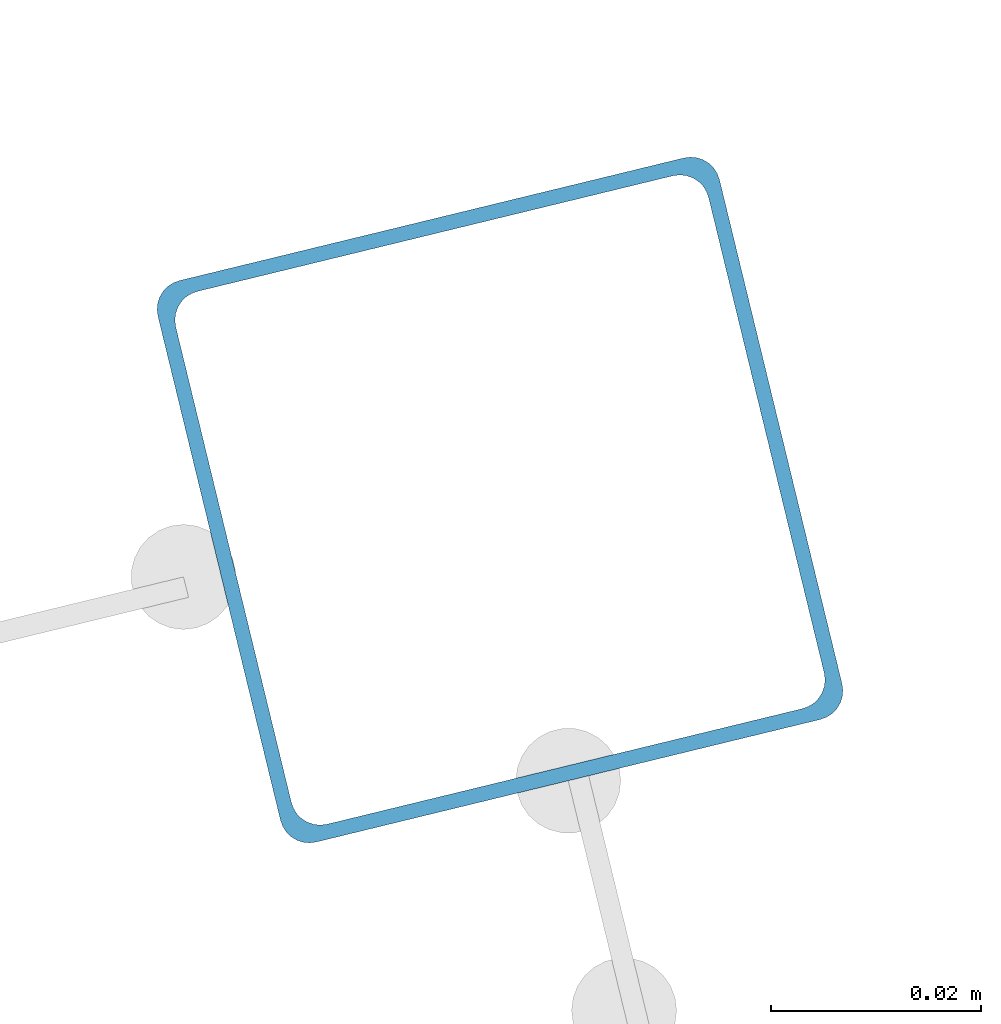
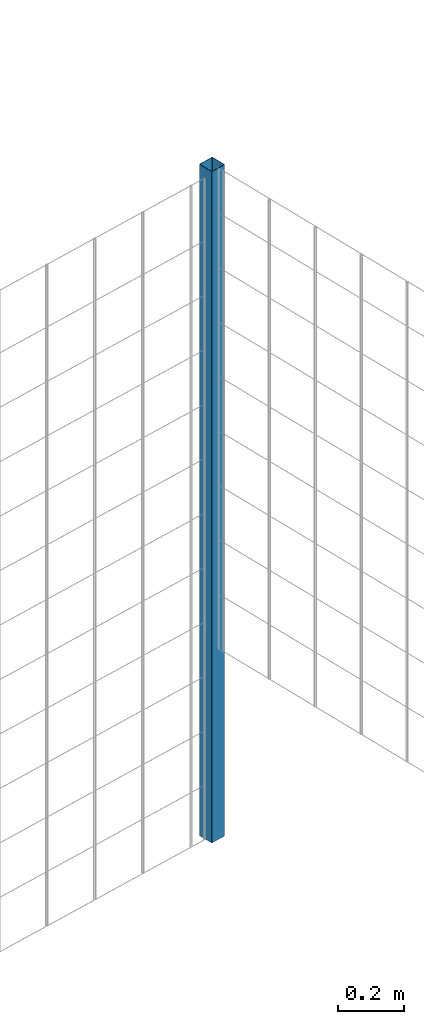
# One storey, part 5 of 10: 1 beam.
"""IFC2X3 building model written with IfcOpenShell, lengths in millimetres."""

import ifcopenshell
import ifcopenshell.guid

model = None  # the IFC model being written
_history = None  # IfcOwnerHistory: only IFC2X3 demands one
_inside = {}  # id of a spatial element -> (the spatial element, [elements in it])
_under = {}  # id of a project, library or spatial element -> (it, [spatial elements below it])
_declared = {}  # id of a project -> (the project, [libraries it declares])
_typed = {}  # id of a type object -> (the type object, [elements of that type])
_made_of = {}  # id of a material, layer set ... -> (it, [elements and type objects made of it])


def new_model(schema):
    """Start an empty IFC model of exactly this schema.

    Asked for "IFC4X3", IfcOpenShell would pick the latest addendum, in which some entities
    have other attributes; the version numbers below select the first issue.
    IFC2X3 requires an IfcOwnerHistory on every rooted entity: one is made here for all.
    """
    global model, _history
    if schema == "IFC4X3":
        model = ifcopenshell.file(schema_version=(4, 3, 0, 0))
    else:
        model = ifcopenshell.file(schema=schema)
    _inside.clear()
    _under.clear()
    _declared.clear()
    _typed.clear()
    _made_of.clear()
    _history = None
    if model.schema == "IFC2X3":
        org = make("IfcOrganization", Name="unknown")
        user = make(
            "IfcPersonAndOrganization",
            ThePerson=make("IfcPerson", FamilyName="unknown"),
            TheOrganization=org,
        )
        app = make(
            "IfcApplication",
            ApplicationDeveloper=org,
            Version="unknown",
            ApplicationFullName="unknown",
            ApplicationIdentifier="unknown",
        )
        _history = make(
            "IfcOwnerHistory",
            OwningUser=user,
            OwningApplication=app,
            ChangeAction="ADDED",
            CreationDate=0,
        )
    return model


def make(cls, **values):
    """One entity of the class cls with the attributes given. An attribute that is None is left unset."""
    return model.create_entity(
        cls, **{name: value for name, value in values.items() if value is not None}
    )


def entity(cls, *values):
    """Any entity or typed value of the class cls, its attributes in the order of the schema. None: left unset."""
    e = model.create_entity(cls)
    for i, value in enumerate(values):
        if value is not None:
            e[i] = value
    return e


def rooted(cls, **values):
    """An entity with a GlobalId (a new one), such as an element, a storey or a relation."""
    return make(cls, GlobalId=ifcopenshell.guid.new(), OwnerHistory=_history, **values)


def si_unit(unit_type, name, prefix=None):
    """IfcSIUnit, for example si_unit("LENGTHUNIT", "METRE", prefix="MILLI")."""
    return make("IfcSIUnit", UnitType=unit_type, Prefix=prefix, Name=name)


def converted_unit(unit_type, name, factor, base, dimensions=None, offset=None):
    """IfcConversionBasedUnit, such as the inch: factor (a typed value) times the base unit."""
    return make(
        "IfcConversionBasedUnit"
        if offset is None
        else "IfcConversionBasedUnitWithOffset",
        ConversionOffset=offset,
        Dimensions=None
        if dimensions is None
        else entity("IfcDimensionalExponents", *dimensions),
        UnitType=unit_type,
        Name=name,
        ConversionFactor=make(
            "IfcMeasureWithUnit", ValueComponent=factor, UnitComponent=base
        ),
    )


def derived_unit(unit_type, elements):
    """IfcDerivedUnit: a product of units, each with its exponent."""
    return make(
        "IfcDerivedUnit",
        Elements=[
            make("IfcDerivedUnitElement", Unit=unit, Exponent=power)
            for unit, power in elements
        ],
        UnitType=unit_type,
    )


def assignment(units):
    """IfcUnitAssignment: the units of a project."""
    return None if units is None else make("IfcUnitAssignment", Units=units)


def point(xyz):
    """IfcCartesianPoint."""
    return None if xyz is None else make("IfcCartesianPoint", Coordinates=xyz)


def direction(xyz):
    """IfcDirection."""
    return None if xyz is None else make("IfcDirection", DirectionRatios=xyz)


def frame(location, z_axis=None, x_axis=None):
    """IfcAxis2Placement3D, a coordinate frame: its origin and axes. An axis left out is left unset."""
    return make(
        "IfcAxis2Placement3D",
        Location=point(location),
        Axis=direction(z_axis),
        RefDirection=direction(x_axis),
    )


def frame_2d(location, x_axis=None):
    """IfcAxis2Placement2D, a coordinate frame in the plane: its origin and x axis."""
    return make(
        "IfcAxis2Placement2D", Location=point(location), RefDirection=direction(x_axis)
    )


def origin():
    """The frame at (0, 0, 0) with its axes left unset."""
    return frame((0.0, 0.0, 0.0))


def place(relative_to, where):
    """IfcLocalPlacement: puts the frame where relative to a parent placement (None: the world)."""
    return make(
        "IfcLocalPlacement", PlacementRelTo=relative_to, RelativePlacement=where
    )


def context(
    kind, dimensions, precision=None, world=None, true_north=None, identifier=None
):
    """IfcGeometricRepresentationContext, for example the 3D "Model" context."""
    return make(
        "IfcGeometricRepresentationContext",
        ContextIdentifier=identifier,
        ContextType=kind,
        CoordinateSpaceDimension=dimensions,
        Precision=precision,
        WorldCoordinateSystem=world,
        TrueNorth=true_north,
    )


def subcontext(parent, identifier, kind, view, scale=None):
    """IfcGeometricRepresentationSubContext, for example "Body" below "Model"."""
    return make(
        "IfcGeometricRepresentationSubContext",
        ContextIdentifier=identifier,
        ContextType=kind,
        ParentContext=parent,
        TargetScale=scale,
        TargetView=view,
    )


def project(units=None, contexts=None):
    """IfcProject with its units and contexts."""
    return rooted(
        "IfcProject",
        Name="project",
        RepresentationContexts=contexts,
        UnitsInContext=assignment(units),
    )


def spatial(cls, under=None, at=None, **own):
    """A site, building, storey or space (cls), placed at a placement, below another one or the project."""
    s = rooted(cls, ObjectPlacement=at, **own)
    if under is not None:
        _under.setdefault(under.id(), (under, []))[1].append(s)
    return s


def polyline(points):
    """IfcPolyline through the points."""
    return make("IfcPolyline", Points=[point(p) for p in points])


def circle_curve(where, radius):
    """IfcCircle in the frame where."""
    return make("IfcCircle", Position=where, Radius=radius)


def parameter(value):
    """IfcParameterValue: where a trimmed curve begins or ends, as a parameter of its basis curve."""
    return model.create_entity("IfcParameterValue", value)


def trimmed(basis, trim1, trim2, sense, master):
    """IfcTrimmedCurve: the piece of a basis curve between two trims."""
    return make(
        "IfcTrimmedCurve",
        BasisCurve=basis,
        Trim1=trim1,
        Trim2=trim2,
        SenseAgreement=sense,
        MasterRepresentation=master,
    )


def segment(curve, same_sense, transition):
    """IfcCompositeCurveSegment."""
    return make(
        "IfcCompositeCurveSegment",
        Transition=transition,
        SameSense=same_sense,
        ParentCurve=curve,
    )


def composite_curve(segments, self_intersect=None):
    """IfcCompositeCurve: segments joined end to end."""
    return make("IfcCompositeCurve", Segments=segments, SelfIntersect=self_intersect)


def outline(outer, holes=None, kind="AREA"):
    """IfcArbitraryClosedProfileDef: a profile drawn as a closed curve; with holes, ...WithVoids."""
    if holes is None:
        return make("IfcArbitraryClosedProfileDef", ProfileType=kind, OuterCurve=outer)
    return make(
        "IfcArbitraryProfileDefWithVoids",
        ProfileType=kind,
        OuterCurve=outer,
        InnerCurves=holes,
    )


def extrude(swept, where, along, depth):
    """IfcExtrudedAreaSolid: the profile swept, set in the frame where, extruded along a direction by depth."""
    return make(
        "IfcExtrudedAreaSolid",
        SweptArea=swept,
        Position=where,
        ExtrudedDirection=direction(along),
        Depth=depth,
    )


def shape(context_of_items, identifier, shape_type, items):
    """IfcShapeRepresentation: the items that make up one representation, for example the "Body"."""
    return make(
        "IfcShapeRepresentation",
        ContextOfItems=context_of_items,
        RepresentationIdentifier=identifier,
        RepresentationType=shape_type,
        Items=items,
    )


def material(Name=None, Category=None):
    """IfcMaterial."""
    return make("IfcMaterial", Name=Name, Category=Category)


def made_of(thing, what):
    """Note that an element or type object is made of a material, layer set ...; save() writes the relation."""
    if what is not None:
        _made_of.setdefault(what.id(), (what, []))[1].append(thing)
    return thing


def type_object(cls, material=None, **own):
    """A type object (cls), such as IfcWallType, which elements share."""
    return made_of(rooted(cls, **own), material)


def element(
    cls,
    number,
    at=None,
    inside=None,
    cuts=None,
    type_object=None,
    material=None,
    context=None,
    identifier="Body",
    shape_type=None,
    held_by="IfcProductDefinitionShape",
    body=None,
    shapes=None,
    **own,
):
    """One element of the class cls, such as IfcWall. Its Tag is "e" and its number.

    at: its placement. inside: the storey or other place that contains it. cuts: it is an
    opening in that element (IfcRelVoidsElement). A single representation is given by context,
    identifier, shape_type and body (its items); several are given by shapes. held_by: the class
    of the entity that holds the representations. save() writes the other relations.
    """
    e = rooted(cls, Tag="e%d" % number, ObjectPlacement=at, **own)
    if body is not None:
        shapes = [shape(context, identifier, shape_type, body)]
    if shapes is not None:
        e.Representation = make(held_by, Representations=shapes)
    if inside is not None:
        _inside.setdefault(inside.id(), (inside, []))[1].append(e)
    if cuts is not None:
        rooted(
            "IfcRelVoidsElement", RelatingBuildingElement=cuts, RelatedOpeningElement=e
        )
    if type_object is not None:
        _typed.setdefault(type_object.id(), (type_object, []))[1].append(e)
    return made_of(e, material)


def aggregate(whole, parts):
    """IfcRelAggregates: a whole, such as a stair, and the parts it consists of."""
    return rooted("IfcRelAggregates", RelatingObject=whole, RelatedObjects=parts)


def save(model, path):
    """Write the relations noted so far, then the file.

    IfcRelAggregates (storeys below a building ...), IfcRelContainedInSpatialStructure (elements
    in a storey), IfcRelDefinesByType, IfcRelAssociatesMaterial and IfcRelDeclares: one each for
    every whole, place, type object, material and project.
    """
    for whole, parts in _under.values():
        aggregate(whole, parts)
    for where, things in _inside.values():
        rooted(
            "IfcRelContainedInSpatialStructure",
            RelatedElements=things,
            RelatingStructure=where,
        )
    for kind, things in _typed.values():
        rooted("IfcRelDefinesByType", RelatedObjects=things, RelatingType=kind)
    for what, things in _made_of.values():
        rooted("IfcRelAssociatesMaterial", RelatedObjects=things, RelatingMaterial=what)
    for by, libraries in _declared.values():
        rooted("IfcRelDeclares", RelatingContext=by, RelatedDefinitions=libraries)
    model.write(path)


model = new_model("IFC2X3")

# Units and contexts
model_context = context("Model", 3, precision=0.01, world=origin(), true_north=direction((6.12303176911189e-17, 1.0)))
body_context = subcontext(model_context, "Body", "Model", "MODEL_VIEW")
ifc_project = project(units=[si_unit("LENGTHUNIT", "METRE", prefix="MILLI"), si_unit("AREAUNIT", "SQUARE_METRE"), si_unit("VOLUMEUNIT", "CUBIC_METRE"), converted_unit("PLANEANGLEUNIT", "DEGREE", entity("IfcRatioMeasure", 0.0174532925199433), si_unit("PLANEANGLEUNIT", "RADIAN"), dimensions=[0, 0, 0, 0, 0, 0, 0]), si_unit("MASSUNIT", "GRAM", prefix="KILO"), derived_unit("MASSDENSITYUNIT", [(si_unit("MASSUNIT", "GRAM", prefix="KILO"), 1), (si_unit("LENGTHUNIT", "METRE"), -3)]), derived_unit("MOMENTOFINERTIAUNIT", [(si_unit("LENGTHUNIT", "METRE"), 4)]), si_unit("TIMEUNIT", "SECOND"), si_unit("FREQUENCYUNIT", "HERTZ"), si_unit("THERMODYNAMICTEMPERATUREUNIT", "DEGREE_CELSIUS"), derived_unit("THERMALTRANSMITTANCEUNIT", [(si_unit("MASSUNIT", "GRAM", prefix="KILO"), 1), (si_unit("THERMODYNAMICTEMPERATUREUNIT", "KELVIN"), -1), (si_unit("TIMEUNIT", "SECOND"), -3)]), derived_unit("VOLUMETRICFLOWRATEUNIT", [(si_unit("LENGTHUNIT", "METRE"), 3), (si_unit("TIMEUNIT", "SECOND"), -1)]), derived_unit("MASSFLOWRATEUNIT", [(si_unit("MASSUNIT", "GRAM", prefix="KILO"), 1), (si_unit("TIMEUNIT", "SECOND"), -1)]), derived_unit("ROTATIONALFREQUENCYUNIT", [(si_unit("TIMEUNIT", "SECOND"), -1)]), si_unit("ELECTRICCURRENTUNIT", "AMPERE"), si_unit("ELECTRICVOLTAGEUNIT", "VOLT"), si_unit("POWERUNIT", "WATT"), si_unit("FORCEUNIT", "NEWTON", prefix="KILO"), si_unit("ILLUMINANCEUNIT", "LUX"), si_unit("LUMINOUSFLUXUNIT", "LUMEN"), si_unit("LUMINOUSINTENSITYUNIT", "CANDELA"), derived_unit("USERDEFINED", [(si_unit("MASSUNIT", "GRAM", prefix="KILO"), -1), (si_unit("LENGTHUNIT", "METRE"), -2), (si_unit("TIMEUNIT", "SECOND"), 3), (si_unit("LUMINOUSFLUXUNIT", "LUMEN"), 1)]), derived_unit("LINEARVELOCITYUNIT", [(si_unit("LENGTHUNIT", "METRE"), 1), (si_unit("TIMEUNIT", "SECOND"), -1)]), si_unit("PRESSUREUNIT", "PASCAL"), derived_unit("USERDEFINED", [(si_unit("LENGTHUNIT", "METRE"), -2), (si_unit("MASSUNIT", "GRAM", prefix="KILO"), 1), (si_unit("TIMEUNIT", "SECOND"), -2)]), derived_unit("LINEARFORCEUNIT", [(si_unit("MASSUNIT", "GRAM", prefix="KILO"), 1), (si_unit("LENGTHUNIT", "METRE"), 1), (si_unit("TIMEUNIT", "SECOND"), -2), (si_unit("LENGTHUNIT", "METRE"), -1)]), derived_unit("PLANARFORCEUNIT", [(si_unit("MASSUNIT", "GRAM", prefix="KILO"), 1), (si_unit("LENGTHUNIT", "METRE"), 1), (si_unit("TIMEUNIT", "SECOND"), -2), (si_unit("LENGTHUNIT", "METRE"), -2)])], contexts=[model_context])

# Site, building, storey
site_placement = place(None, frame((19171.75, -72498.58, 0.0), z_axis=(0.0, 0.0, 1.0), x_axis=(0.971695960795463, 0.236234967296933, 0.0)))
site = spatial("IfcSite", under=ifc_project, at=site_placement, CompositionType="ELEMENT")
building_placement = place(site_placement, origin())
building = spatial("IfcBuilding", under=site, at=building_placement, CompositionType="ELEMENT")
storey_placement = place(building_placement, origin())
storey = spatial("IfcBuildingStorey", under=building, at=storey_placement, Name="01", CompositionType="ELEMENT", Elevation=0.0)

# Beam
ifc_material = material(Name="345")
beam_type = type_object("IfcBeamType", PredefinedType="NOTDEFINED")
beam_placement = place(storey_placement, frame((9845.9, 5570.9, 0.0), z_axis=(1.0, 0.0, 0.0), x_axis=(0.0, 0.0, -1.0)))
element("IfcBeam", 1, at=beam_placement, inside=storey, type_object=beam_type, material=ifc_material, context=body_context, shape_type="SweptSolid", body=[
    extrude(outline(composite_curve([segment(trimmed(circle_curve(frame_2d((24.7, -24.7), x_axis=(1.0, 0.0)), 2.79999999999974), [parameter(269.999999999999)], [parameter(1.32311074748882e-12)], True, "PARAMETER"), True, "CONTINUOUS"), segment(polyline([(27.5, -24.7), (27.5, 24.7)]), True, "CONTINUOUS"), segment(trimmed(circle_curve(frame_2d((24.7, 24.7), x_axis=(1.0, 0.0)), 2.79999999999845), [parameter(1.32311074748882e-12)], [parameter(90.0000000000001)], True, "PARAMETER"), True, "CONTINUOUS"), segment(polyline([(24.7, 27.5), (-24.7, 27.5)]), True, "CONTINUOUS"), segment(trimmed(circle_curve(frame_2d((-24.7, 24.7), x_axis=(1.0, 0.0)), 2.79999999999845), [parameter(90.0000000000001)], [parameter(180.0)], True, "PARAMETER"), True, "CONTINUOUS"), segment(polyline([(-27.5, 24.7), (-27.5, -24.7)]), True, "CONTINUOUS"), segment(trimmed(circle_curve(frame_2d((-24.7, -24.7), x_axis=(1.0, 0.0)), 2.79999999999845), [parameter(180.0)], [parameter(269.999999999998)], True, "PARAMETER"), True, "CONTINUOUS"), segment(polyline([(-24.7, -27.5), (24.7, -27.5)]), True, "CONTINUOUS")], self_intersect=False), holes=[composite_curve([segment(polyline([(23.3, -26.1), (-23.3, -26.1)]), True, "CONTINUOUS"), segment(trimmed(circle_curve(frame_2d((-23.3, -23.3), x_axis=(1.0, 0.0)), 2.79999999999973), [parameter(180.0)], [parameter(270.0)], True, "PARAMETER"), False, "CONTINUOUS"), segment(polyline([(-26.1, -23.3), (-26.1, 23.3)]), True, "CONTINUOUS"), segment(trimmed(circle_curve(frame_2d((-23.3, 23.3), x_axis=(1.0, 0.0)), 2.79999999999973), [parameter(90.0000000000004)], [parameter(180.0)], True, "PARAMETER"), False, "CONTINUOUS"), segment(polyline([(-23.3, 26.1), (23.3, 26.1)]), True, "CONTINUOUS"), segment(trimmed(circle_curve(frame_2d((23.3, 23.3), x_axis=(1.0, 0.0)), 2.79999999999973), [parameter(3.56222124323914e-13)], [parameter(90.0000000000004)], True, "PARAMETER"), False, "CONTINUOUS"), segment(polyline([(26.1, 23.3), (26.1, -23.3)]), True, "CONTINUOUS"), segment(trimmed(circle_curve(frame_2d((23.3, -23.3), x_axis=(1.0, 0.0)), 2.80000000000034), [parameter(270.0)], [parameter(4.57999874130747e-13)], True, "PARAMETER"), False, "CONTINUOUS")], self_intersect=False)]), frame((-2465.98, 29.1, 29.1), z_axis=(1.0, 0.0, 0.0), x_axis=(0.0, 1.0, 0.0)), (0.0, 0.0, 1.0), 2465.97922445826),
])

save(model, "model.ifc")
